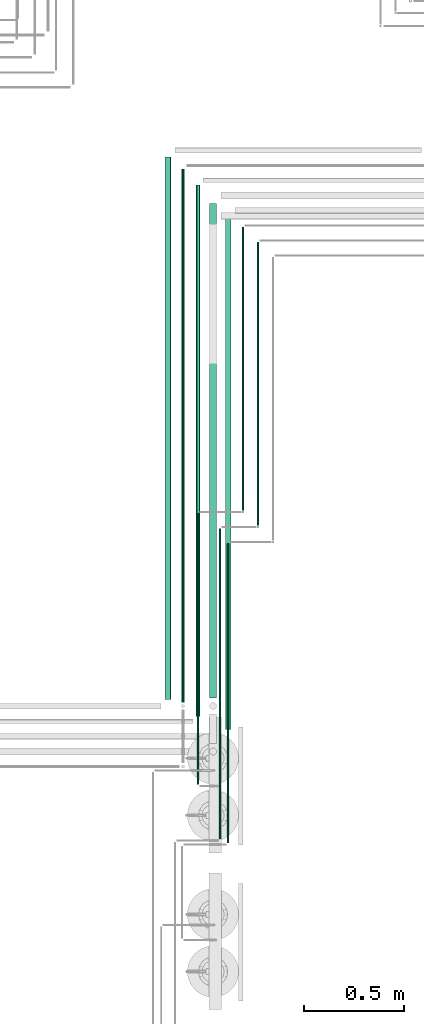
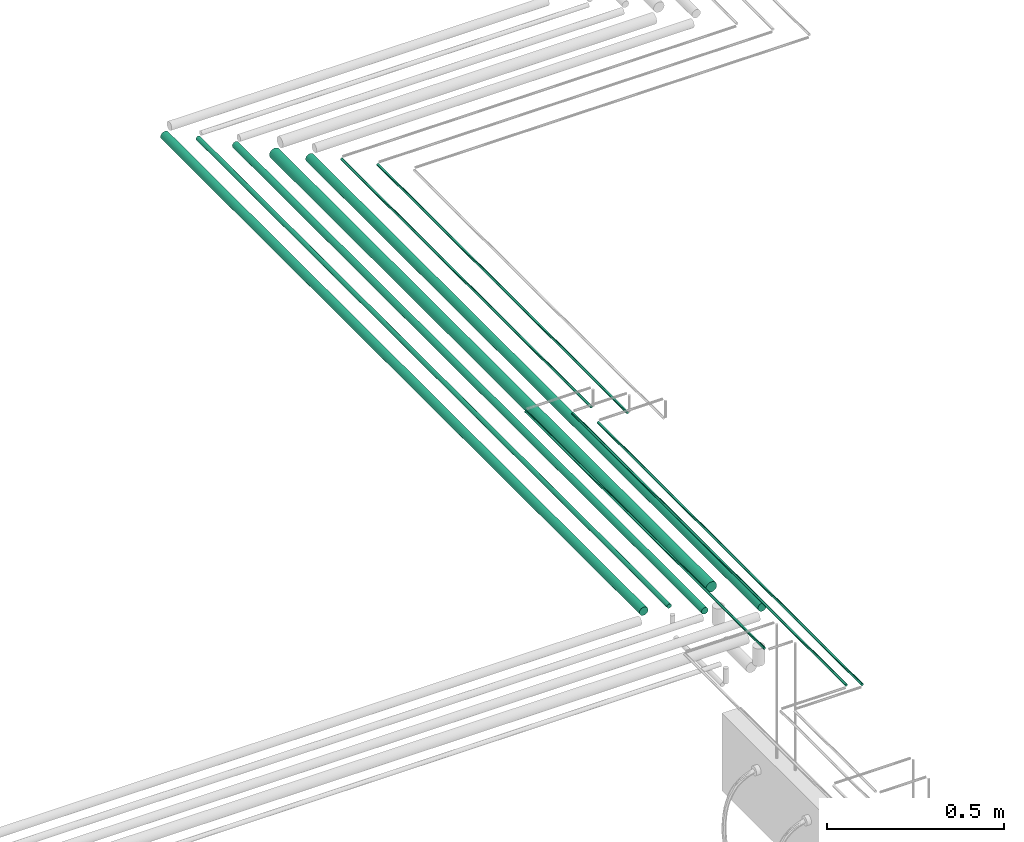
# One storey, part 66 of 331: 10 flow segments.
"""IFC2X3 building model written with IfcOpenShell, lengths in millimetres."""

import ifcopenshell
import ifcopenshell.guid

model = None  # the IFC model being written
_history = None  # IfcOwnerHistory: only IFC2X3 demands one
_inside = {}  # id of a spatial element -> (the spatial element, [elements in it])
_under = {}  # id of a project, library or spatial element -> (it, [spatial elements below it])
_declared = {}  # id of a project -> (the project, [libraries it declares])
_typed = {}  # id of a type object -> (the type object, [elements of that type])
_made_of = {}  # id of a material, layer set ... -> (it, [elements and type objects made of it])


def new_model(schema):
    """Start an empty IFC model of exactly this schema.

    Asked for "IFC4X3", IfcOpenShell would pick the latest addendum, in which some entities
    have other attributes; the version numbers below select the first issue.
    IFC2X3 requires an IfcOwnerHistory on every rooted entity: one is made here for all.
    """
    global model, _history
    if schema == "IFC4X3":
        model = ifcopenshell.file(schema_version=(4, 3, 0, 0))
    else:
        model = ifcopenshell.file(schema=schema)
    _inside.clear()
    _under.clear()
    _declared.clear()
    _typed.clear()
    _made_of.clear()
    _history = None
    if model.schema == "IFC2X3":
        org = make("IfcOrganization", Name="unknown")
        user = make(
            "IfcPersonAndOrganization",
            ThePerson=make("IfcPerson", FamilyName="unknown"),
            TheOrganization=org,
        )
        app = make(
            "IfcApplication",
            ApplicationDeveloper=org,
            Version="unknown",
            ApplicationFullName="unknown",
            ApplicationIdentifier="unknown",
        )
        _history = make(
            "IfcOwnerHistory",
            OwningUser=user,
            OwningApplication=app,
            ChangeAction="ADDED",
            CreationDate=0,
        )
    return model


def make(cls, **values):
    """One entity of the class cls with the attributes given. An attribute that is None is left unset."""
    return model.create_entity(
        cls, **{name: value for name, value in values.items() if value is not None}
    )


def entity(cls, *values):
    """Any entity or typed value of the class cls, its attributes in the order of the schema. None: left unset."""
    e = model.create_entity(cls)
    for i, value in enumerate(values):
        if value is not None:
            e[i] = value
    return e


def rooted(cls, **values):
    """An entity with a GlobalId (a new one), such as an element, a storey or a relation."""
    return make(cls, GlobalId=ifcopenshell.guid.new(), OwnerHistory=_history, **values)


def si_unit(unit_type, name, prefix=None):
    """IfcSIUnit, for example si_unit("LENGTHUNIT", "METRE", prefix="MILLI")."""
    return make("IfcSIUnit", UnitType=unit_type, Prefix=prefix, Name=name)


def converted_unit(unit_type, name, factor, base, dimensions=None, offset=None):
    """IfcConversionBasedUnit, such as the inch: factor (a typed value) times the base unit."""
    return make(
        "IfcConversionBasedUnit"
        if offset is None
        else "IfcConversionBasedUnitWithOffset",
        ConversionOffset=offset,
        Dimensions=None
        if dimensions is None
        else entity("IfcDimensionalExponents", *dimensions),
        UnitType=unit_type,
        Name=name,
        ConversionFactor=make(
            "IfcMeasureWithUnit", ValueComponent=factor, UnitComponent=base
        ),
    )


def derived_unit(unit_type, elements):
    """IfcDerivedUnit: a product of units, each with its exponent."""
    return make(
        "IfcDerivedUnit",
        Elements=[
            make("IfcDerivedUnitElement", Unit=unit, Exponent=power)
            for unit, power in elements
        ],
        UnitType=unit_type,
    )


def assignment(units):
    """IfcUnitAssignment: the units of a project."""
    return None if units is None else make("IfcUnitAssignment", Units=units)


def point(xyz):
    """IfcCartesianPoint."""
    return None if xyz is None else make("IfcCartesianPoint", Coordinates=xyz)


def direction(xyz):
    """IfcDirection."""
    return None if xyz is None else make("IfcDirection", DirectionRatios=xyz)


def frame(location, z_axis=None, x_axis=None):
    """IfcAxis2Placement3D, a coordinate frame: its origin and axes. An axis left out is left unset."""
    return make(
        "IfcAxis2Placement3D",
        Location=point(location),
        Axis=direction(z_axis),
        RefDirection=direction(x_axis),
    )


def frame_2d(location, x_axis=None):
    """IfcAxis2Placement2D, a coordinate frame in the plane: its origin and x axis."""
    return make(
        "IfcAxis2Placement2D", Location=point(location), RefDirection=direction(x_axis)
    )


def origin():
    """The frame at (0, 0, 0) with its axes left unset."""
    return frame((0.0, 0.0, 0.0))


def origin_2d_with_axis():
    """The frame at (0, 0) in the plane with the x axis (1, 0) written out."""
    return frame_2d((0.0, 0.0), x_axis=(1.0, 0.0))


def place(relative_to, where):
    """IfcLocalPlacement: puts the frame where relative to a parent placement (None: the world)."""
    return make(
        "IfcLocalPlacement", PlacementRelTo=relative_to, RelativePlacement=where
    )


def context(
    kind, dimensions, precision=None, world=None, true_north=None, identifier=None
):
    """IfcGeometricRepresentationContext, for example the 3D "Model" context."""
    return make(
        "IfcGeometricRepresentationContext",
        ContextIdentifier=identifier,
        ContextType=kind,
        CoordinateSpaceDimension=dimensions,
        Precision=precision,
        WorldCoordinateSystem=world,
        TrueNorth=true_north,
    )


def subcontext(parent, identifier, kind, view, scale=None):
    """IfcGeometricRepresentationSubContext, for example "Body" below "Model"."""
    return make(
        "IfcGeometricRepresentationSubContext",
        ContextIdentifier=identifier,
        ContextType=kind,
        ParentContext=parent,
        TargetScale=scale,
        TargetView=view,
    )


def project(units=None, contexts=None):
    """IfcProject with its units and contexts."""
    return rooted(
        "IfcProject",
        Name="project",
        RepresentationContexts=contexts,
        UnitsInContext=assignment(units),
    )


def spatial(cls, under=None, at=None, **own):
    """A site, building, storey or space (cls), placed at a placement, below another one or the project."""
    s = rooted(cls, ObjectPlacement=at, **own)
    if under is not None:
        _under.setdefault(under.id(), (under, []))[1].append(s)
    return s


def profile(cls, at=None, kind="AREA", **sizes):
    """A parametric profile (cls). Its sizes go by their IFC names, for example OverallWidth=200.0."""
    return make(cls, ProfileType=kind, Position=at, **sizes)


def circle(**sizes):
    """IfcCircleProfileDef."""
    return profile("IfcCircleProfileDef", **sizes)


def extrude(swept, where, along, depth):
    """IfcExtrudedAreaSolid: the profile swept, set in the frame where, extruded along a direction by depth."""
    return make(
        "IfcExtrudedAreaSolid",
        SweptArea=swept,
        Position=where,
        ExtrudedDirection=direction(along),
        Depth=depth,
    )


def shape(context_of_items, identifier, shape_type, items):
    """IfcShapeRepresentation: the items that make up one representation, for example the "Body"."""
    return make(
        "IfcShapeRepresentation",
        ContextOfItems=context_of_items,
        RepresentationIdentifier=identifier,
        RepresentationType=shape_type,
        Items=items,
    )


def made_of(thing, what):
    """Note that an element or type object is made of a material, layer set ...; save() writes the relation."""
    if what is not None:
        _made_of.setdefault(what.id(), (what, []))[1].append(thing)
    return thing


def type_object(cls, material=None, **own):
    """A type object (cls), such as IfcWallType, which elements share."""
    return made_of(rooted(cls, **own), material)


def element(
    cls,
    number,
    at=None,
    inside=None,
    cuts=None,
    type_object=None,
    material=None,
    context=None,
    identifier="Body",
    shape_type=None,
    held_by="IfcProductDefinitionShape",
    body=None,
    shapes=None,
    **own,
):
    """One element of the class cls, such as IfcWall. Its Tag is "e" and its number.

    at: its placement. inside: the storey or other place that contains it. cuts: it is an
    opening in that element (IfcRelVoidsElement). A single representation is given by context,
    identifier, shape_type and body (its items); several are given by shapes. held_by: the class
    of the entity that holds the representations. save() writes the other relations.
    """
    e = rooted(cls, Tag="e%d" % number, ObjectPlacement=at, **own)
    if body is not None:
        shapes = [shape(context, identifier, shape_type, body)]
    if shapes is not None:
        e.Representation = make(held_by, Representations=shapes)
    if inside is not None:
        _inside.setdefault(inside.id(), (inside, []))[1].append(e)
    if cuts is not None:
        rooted(
            "IfcRelVoidsElement", RelatingBuildingElement=cuts, RelatedOpeningElement=e
        )
    if type_object is not None:
        _typed.setdefault(type_object.id(), (type_object, []))[1].append(e)
    return made_of(e, material)


def aggregate(whole, parts):
    """IfcRelAggregates: a whole, such as a stair, and the parts it consists of."""
    return rooted("IfcRelAggregates", RelatingObject=whole, RelatedObjects=parts)


def save(model, path):
    """Write the relations noted so far, then the file.

    IfcRelAggregates (storeys below a building ...), IfcRelContainedInSpatialStructure (elements
    in a storey), IfcRelDefinesByType, IfcRelAssociatesMaterial and IfcRelDeclares: one each for
    every whole, place, type object, material and project.
    """
    for whole, parts in _under.values():
        aggregate(whole, parts)
    for where, things in _inside.values():
        rooted(
            "IfcRelContainedInSpatialStructure",
            RelatedElements=things,
            RelatingStructure=where,
        )
    for kind, things in _typed.values():
        rooted("IfcRelDefinesByType", RelatedObjects=things, RelatingType=kind)
    for what, things in _made_of.values():
        rooted("IfcRelAssociatesMaterial", RelatedObjects=things, RelatingMaterial=what)
    for by, libraries in _declared.values():
        rooted("IfcRelDeclares", RelatingContext=by, RelatedDefinitions=libraries)
    model.write(path)


model = new_model("IFC2X3")

# Units and contexts
model_context = context("Model", 3, precision=0.01, world=origin(), true_north=direction((6.12303176911189e-17, 1.0)))
body_context = subcontext(model_context, "Body", "Model", "MODEL_VIEW")
ifc_project = project(units=[si_unit("LENGTHUNIT", "METRE", prefix="MILLI"), si_unit("AREAUNIT", "SQUARE_METRE"), si_unit("VOLUMEUNIT", "CUBIC_METRE"), converted_unit("PLANEANGLEUNIT", "DEGREE", entity("IfcRatioMeasure", 0.0174532925199433), si_unit("PLANEANGLEUNIT", "RADIAN"), dimensions=[0, 0, 0, 0, 0, 0, 0]), si_unit("MASSUNIT", "GRAM", prefix="KILO"), derived_unit("MASSDENSITYUNIT", [(si_unit("MASSUNIT", "GRAM", prefix="KILO"), 1), (si_unit("LENGTHUNIT", "METRE"), -3)]), derived_unit("MOMENTOFINERTIAUNIT", [(si_unit("LENGTHUNIT", "METRE"), 4)]), si_unit("TIMEUNIT", "SECOND"), si_unit("FREQUENCYUNIT", "HERTZ"), si_unit("THERMODYNAMICTEMPERATUREUNIT", "DEGREE_CELSIUS"), derived_unit("THERMALTRANSMITTANCEUNIT", [(si_unit("MASSUNIT", "GRAM", prefix="KILO"), 1), (si_unit("THERMODYNAMICTEMPERATUREUNIT", "KELVIN"), -1), (si_unit("TIMEUNIT", "SECOND"), -3)]), derived_unit("VOLUMETRICFLOWRATEUNIT", [(si_unit("LENGTHUNIT", "METRE"), 3), (si_unit("TIMEUNIT", "SECOND"), -1)]), derived_unit("MASSFLOWRATEUNIT", [(si_unit("MASSUNIT", "GRAM", prefix="KILO"), 1), (si_unit("TIMEUNIT", "SECOND"), -1)]), derived_unit("ROTATIONALFREQUENCYUNIT", [(si_unit("TIMEUNIT", "SECOND"), -1)]), si_unit("ELECTRICCURRENTUNIT", "AMPERE"), si_unit("ELECTRICVOLTAGEUNIT", "VOLT"), si_unit("POWERUNIT", "WATT"), si_unit("FORCEUNIT", "NEWTON", prefix="KILO"), si_unit("ILLUMINANCEUNIT", "LUX"), si_unit("LUMINOUSFLUXUNIT", "LUMEN"), si_unit("LUMINOUSINTENSITYUNIT", "CANDELA"), derived_unit("USERDEFINED", [(si_unit("MASSUNIT", "GRAM", prefix="KILO"), -1), (si_unit("LENGTHUNIT", "METRE"), -2), (si_unit("TIMEUNIT", "SECOND"), 3), (si_unit("LUMINOUSFLUXUNIT", "LUMEN"), 1)]), derived_unit("LINEARVELOCITYUNIT", [(si_unit("LENGTHUNIT", "METRE"), 1), (si_unit("TIMEUNIT", "SECOND"), -1)]), si_unit("PRESSUREUNIT", "PASCAL"), derived_unit("USERDEFINED", [(si_unit("LENGTHUNIT", "METRE"), -2), (si_unit("MASSUNIT", "GRAM", prefix="KILO"), 1), (si_unit("TIMEUNIT", "SECOND"), -2)]), derived_unit("LINEARFORCEUNIT", [(si_unit("MASSUNIT", "GRAM", prefix="KILO"), 1), (si_unit("LENGTHUNIT", "METRE"), 1), (si_unit("TIMEUNIT", "SECOND"), -2), (si_unit("LENGTHUNIT", "METRE"), -1)]), derived_unit("PLANARFORCEUNIT", [(si_unit("MASSUNIT", "GRAM", prefix="KILO"), 1), (si_unit("LENGTHUNIT", "METRE"), 1), (si_unit("TIMEUNIT", "SECOND"), -2), (si_unit("LENGTHUNIT", "METRE"), -2)])], contexts=[model_context])

# Site, building, storey
site_placement = place(None, frame((0.0, -0.00077364408347762, 0.0)))
site = spatial("IfcSite", under=ifc_project, at=site_placement, CompositionType="ELEMENT")
building_placement = place(site_placement, origin())
building = spatial("IfcBuilding", under=site, at=building_placement, CompositionType="ELEMENT")
storey_placement = place(building_placement, origin())
storey = spatial("IfcBuildingStorey", under=building, at=storey_placement, CompositionType="ELEMENT", Elevation=0.0)

# Flow segments
pipe_segment_type = type_object("IfcPipeSegmentType", PredefinedType="NOTDEFINED")
flow_segment_1_placement = place(building_placement, frame((64090.9083446482, -625.299201176873, 2840.90472776409)))
element("IfcFlowSegment", 1, at=flow_segment_1_placement, inside=storey, type_object=pipe_segment_type, context=body_context, shape_type="SweptSolid", body=[
    extrude(circle(Radius=7.5, at=frame_2d((-9.76067884967825e-43, 5.41433564649196e-13), x_axis=(1.0, 0.0))), frame((9.09527223592286, 0.0, 9.0952722359169), z_axis=(0.0, 1.0, 0.0), x_axis=(-1.0, 0.0, 0.0)), (0.0, 0.0, 1.0), 2662.04913077139),
])
flow_segment_2_placement = place(building_placement, frame((64162.4083446482, -696.130122350302, 2837.40472776409)))
element("IfcFlowSegment", 2, at=flow_segment_2_placement, inside=storey, type_object=pipe_segment_type, context=body_context, shape_type="SweptSolid", body=[
    extrude(circle(Radius=11.0, at=origin_2d_with_axis()), frame((12.5952722359307, 0.0, 12.5952722359161), z_axis=(0.0, 1.0, 0.0), x_axis=(1.0, 0.0, 0.0)), (0.0, 0.0, 1.0), 2651.88005194482),
])
flow_segment_3_placement = place(building_placement, frame((64230.9083446482, -603.299201176856, 2830.90472776409)))
element("IfcFlowSegment", 3, at=flow_segment_3_placement, inside=storey, type_object=pipe_segment_type, context=body_context, shape_type="SweptSolid", body=[
    extrude(circle(Radius=17.5, at=frame_2d((-1.05929670527262e-42, 5.41433564649196e-13), x_axis=(1.0, 0.0))), frame((19.0952722359206, 0.0, 19.0952722359168), z_axis=(0.0, 1.0, 0.0), x_axis=(-1.0, 0.0, 0.0)), (0.0, 0.0, 1.0), 2468.04913077137),
])
flow_segment_4_placement = place(building_placement, frame((64309.4083446482, -761.130122350311, 2834.40472776409)))
element("IfcFlowSegment", 4, at=flow_segment_4_placement, inside=storey, type_object=pipe_segment_type, context=body_context, shape_type="SweptSolid", body=[
    extrude(circle(Radius=14.0, at=frame_2d((0.0, -1.67016930031556e-28), x_axis=(1.0, 0.0))), frame((15.5952722359474, 0.0, 15.595272235916), z_axis=(0.0, 1.0, 0.0), x_axis=(1.0, 0.0, 0.0)), (0.0, 0.0, 1.0), 2556.88005194481),
])
flow_segment_5_placement = place(building_placement, frame((64393.9020185356, 334.0, 2844.40472776409)))
element("IfcFlowSegment", 5, at=flow_segment_5_placement, inside=storey, type_object=pipe_segment_type, context=body_context, shape_type="SweptSolid", body=[
    extrude(circle(Radius=4.0, at=origin_2d_with_axis()), frame((5.59527223593232, 0.0, 5.59527223591607), z_axis=(0.0, 1.0, 0.0), x_axis=(1.0, 0.0, 0.0)), (0.0, 0.0, 1.0), 1411.74992959433),
])
flow_segment_6_placement = place(building_placement, frame((64468.9020185356, 259.0, 2844.40472776407)))
element("IfcFlowSegment", 6, at=flow_segment_6_placement, inside=storey, type_object=pipe_segment_type, context=body_context, shape_type="SweptSolid", body=[
    extrude(circle(Radius=4.0, at=frame_2d((0.0, -4.64272537640393e-29), x_axis=(1.0, 0.0))), frame((5.59527223593232, 0.0, 5.59527223591607), z_axis=(0.0, 1.0, 0.0), x_axis=(1.0, 0.0, 0.0)), (0.0, 0.0, 1.0), 1411.74992959432),
])
flow_segment_7_placement = place(building_placement, frame((64169.4083446482, -1033.4999999998, 2919.40472776408)))
element("IfcFlowSegment", 7, at=flow_segment_7_placement, inside=storey, type_object=pipe_segment_type, context=body_context, shape_type="SweptSolid", body=[
    extrude(circle(Radius=4.0, at=origin_2d_with_axis()), frame((5.59527223591499, 0.0, 5.59527223591607), z_axis=(0.0, 1.0, 0.0), x_axis=(-1.0, 0.0, 0.0)), (0.0, 0.0, 1.0), 1349.5),
])
flow_segment_8_placement = place(building_placement, frame((64009.4083446482, -611.130122350295, 2834.40472776411)))
element("IfcFlowSegment", 8, at=flow_segment_8_placement, inside=storey, type_object=pipe_segment_type, context=body_context, shape_type="SweptSolid", body=[
    extrude(circle(Radius=14.0, at=origin_2d_with_axis()), frame((15.5952722359127, 0.0, 15.595272235916), z_axis=(0.0, 1.0, 0.0), x_axis=(-1.0, 0.0, 0.0)), (0.0, 0.0, 1.0), 2706.88005194481),
])
flow_segment_9_placement = place(storey_placement, frame((64319.4083446479, -1326.0, 2919.40472776408)))
element("IfcFlowSegment", 9, at=flow_segment_9_placement, inside=storey, type_object=pipe_segment_type, context=body_context, shape_type="SweptSolid", body=[
    extrude(circle(Radius=4.0, at=frame_2d((1.8192167772213e-10, 0.0), x_axis=(1.0, 0.0))), frame((5.59527223610557, 0.0, 5.59527223591607), z_axis=(0.0, 1.0, 0.0), x_axis=(-1.0, 0.0, 0.0)), (0.0, 0.0, 1.0), 1492.0),
])
flow_segment_10_placement = place(storey_placement, frame((64279.4083446481, -1306.0, 2919.40472776408)))
element("IfcFlowSegment", 10, at=flow_segment_10_placement, inside=storey, type_object=pipe_segment_type, context=body_context, shape_type="SweptSolid", body=[
    extrude(circle(Radius=4.0, at=frame_2d((7.79664333094843e-11, 0.0), x_axis=(1.0, 0.0))), frame((5.59527223598429, 0.0, 5.59527223591607), z_axis=(0.0, 1.0, 0.0), x_axis=(-1.0, 0.0, 0.0)), (0.0, 0.0, 1.0), 1547.00000000001),
])

save(model, "model.ifc")
